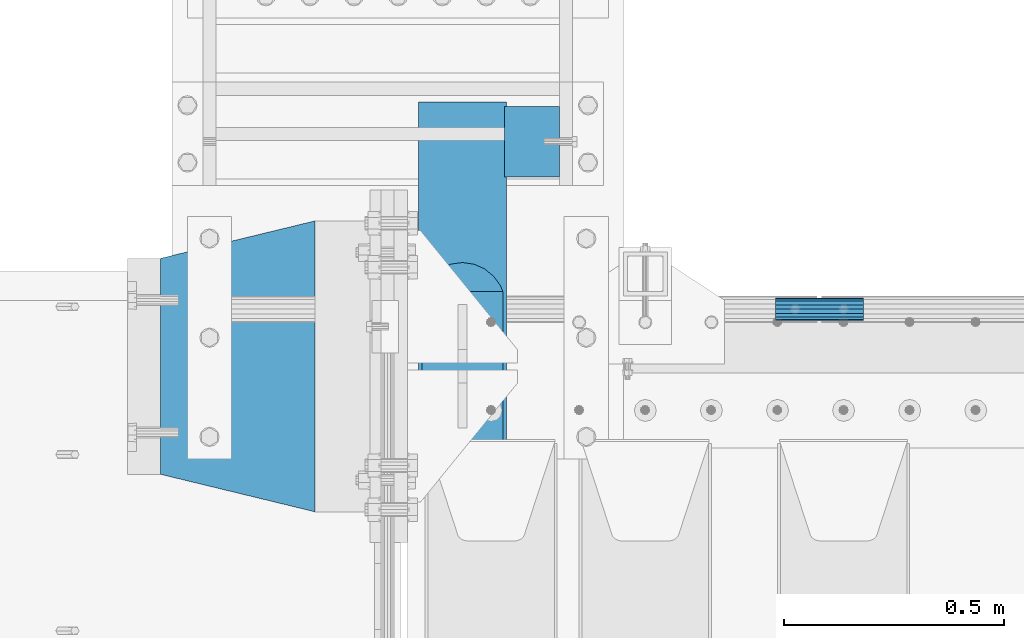
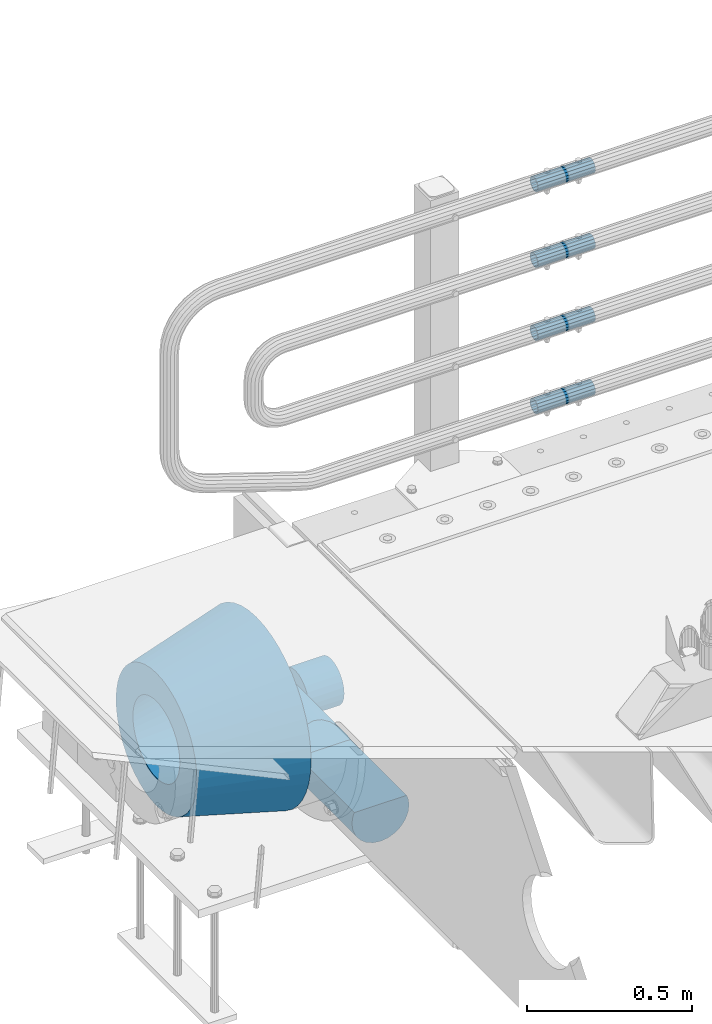
# One storey, part 113 of 193: 7 beams.
"""IFC2X3 building model written with IfcOpenShell, lengths in millimetres."""

from ifc_helpers import new_model, si_unit, frame, origin_with_axes, place, context, subcontext, project, spatial, faceted_brep, material, type_object, element, save


model = new_model("IFC2X3")

# Units and contexts
model_context = context("Model", 3, precision=1e-05, world=origin_with_axes())
body_context = subcontext(model_context, "Body", "Model", "MODEL_VIEW")
ifc_project = project(units=[si_unit("LENGTHUNIT", "METRE", prefix="MILLI"), si_unit("AREAUNIT", "SQUARE_METRE"), si_unit("VOLUMEUNIT", "CUBIC_METRE"), si_unit("MASSUNIT", "GRAM", prefix="KILO"), si_unit("TIMEUNIT", "SECOND"), si_unit("PLANEANGLEUNIT", "RADIAN"), si_unit("SOLIDANGLEUNIT", "STERADIAN"), si_unit("THERMODYNAMICTEMPERATUREUNIT", "DEGREE_CELSIUS"), si_unit("LUMINOUSINTENSITYUNIT", "LUMEN")], contexts=[model_context])

# Site, building, storey
site_placement = place(None, origin_with_axes())
site = spatial("IfcSite", under=ifc_project, at=site_placement, CompositionType="ELEMENT")
building_placement = place(site_placement, origin_with_axes())
building = spatial("IfcBuilding", under=site, at=building_placement, Name="Standard", CompositionType="ELEMENT")
storey_placement = place(building_placement, origin_with_axes())
storey = spatial("IfcBuildingStorey", under=building, at=storey_placement, Name="Undefined", CompositionType="ELEMENT", Elevation=0.0)

# Beams
ifc_material_1 = material(Name="STEEL/S355N")
beam_type_1 = type_object("IfcBeamType", Name="D200", PredefinedType="NOTDEFINED")
beam_1_placement = place(storey_placement, frame((-42315.0, 30600.0, -928.0), z_axis=(0.0, 0.0, 1.0), x_axis=(0.0, -1.0, 0.0)))
element("IfcBeam", 1, at=beam_1_placement, inside=storey, type_object=beam_type_1, material=ifc_material_1, ObjectType="D200", context=body_context, shape_type="Brep", body=[
    faceted_brep([(430.0, 91.573103126917, 38.0), (430.0, -91.5731031269243, 38.0), (770.0, -91.5731031269243, 37.9999999999994), (770.0, 91.5731031269243, 37.9999999999994), (417.294117647056, 86.6025403784442, 50.0), (395.365164344952, 70.7106781186521, 70.7106781186548), (378.538486658119, 50.0, 86.6025403784439), (367.960794863509, 25.88190451025, 96.5925826289068), (364.352941176472, 0.0, 100.0), (367.960794863509, -25.88190451025, 96.5925826289068), (378.538486658119, -50.0, 86.6025403784439), (395.365164344952, -70.7106781186521, 70.7106781186548), (417.294117647056, -86.6025403784442, 50.0), (0.0, -96.5925826289094, 25.8819045102521), (0.0, -100.0, 0.0), (770.0, -100.0, 0.0), (770.0, -96.5925826289094, 25.8819045102521), (0.0, 96.5925826289094, -25.8819045102521), (0.0, 100.0, 0.0), (770.0, 100.0, 0.0), (770.0, 96.5925826289094, -25.8819045102521), (0.0, 86.6025403784442, -50.0), (770.0, 86.6025403784442, -50.0), (0.0, 70.7106781186521, -70.7106781186548), (770.0, 70.7106781186521, -70.7106781186548), (0.0, 50.0, -86.6025403784438), (770.0, 50.0, -86.6025403784438), (0.0, 25.88190451025, -96.5925826289067), (770.0, 25.88190451025, -96.5925826289067), (0.0, 0.0, -100.0), (770.0, 0.0, -100.0), (0.0, -25.88190451025, -96.5925826289069), (770.0, -25.88190451025, -96.5925826289069), (0.0, -50.0, -86.6025403784439), (770.0, -50.0, -86.6025403784439), (0.0, -70.7106781186521, -70.7106781186548), (770.0, -70.7106781186521, -70.7106781186548), (0.0, -86.6025403784442, -50.0), (770.0, -86.6025403784442, -50.0), (0.0, -96.5925826289094, -25.8819045102522), (770.0, -96.5925826289094, -25.8819045102522), (0.0, -86.6025403784442, 50.0), (0.0, -70.7106781186521, 70.7106781186548), (0.0, -50.0, 86.6025403784439), (0.0, -25.88190451025, 96.5925826289068), (0.0, 0.0, 100.0), (0.0, 25.88190451025, 96.5925826289068), (0.0, 50.0, 86.6025403784439), (0.0, 70.7106781186521, 70.7106781186548), (0.0, 86.6025403784442, 50.0), (0.0, 96.5925826289094, 25.8819045102521), (770.0, 96.5925826289094, 25.8819045102521)], [[[0, 1, 2, 3]], [[4, 5, 6, 7, 8, 9, 10, 11, 12, 1, 0]], [[13, 14, 15, 16]], [[17, 18, 19, 20]], [[21, 17, 20, 22]], [[23, 21, 22, 24]], [[25, 23, 24, 26]], [[27, 25, 26, 28]], [[29, 27, 28, 30]], [[31, 29, 30, 32]], [[33, 31, 32, 34]], [[35, 33, 34, 36]], [[37, 35, 36, 38]], [[39, 37, 38, 40]], [[14, 39, 40, 15]], [[13, 41, 42, 43, 44, 45, 46, 47, 48, 49, 50, 18, 17, 21, 23, 25, 27, 29, 31, 33, 35, 37, 39, 14]], [[18, 50, 51, 19]], [[16, 15, 40, 38, 36, 34, 32, 30, 28, 26, 24, 22, 20, 19, 51, 3, 2]], [[41, 13, 16, 2, 1, 12]], [[42, 41, 12, 11]], [[43, 42, 11, 10]], [[44, 43, 10, 9]], [[45, 44, 9, 8]], [[46, 45, 8, 7]], [[47, 46, 7, 6]], [[48, 47, 6, 5]], [[49, 48, 5, 4]], [[51, 50, 49, 4, 0, 3]]]),
])
ifc_material_2 = material()
beam_type_2 = type_object("IfcBeamType", PredefinedType="NOTDEFINED")
beam_2_placement = place(storey_placement, frame((-42220.0000000006, 30509.9999999997, -923.000000000004), z_axis=(0.0, 0.0, 1.0), x_axis=(1.0, 0.0, 0.0)))
element("IfcBeam", 2, at=beam_2_placement, inside=storey, type_object=beam_type_2, material=ifc_material_2, context=body_context, shape_type="Brep", body=[
    faceted_brep([(0.0, -80.0, 0.0), (0.0, -77.2740661031239, -20.7055236082017), (125.0, -77.2740661031239, -20.7055236082017), (125.0, -80.0, 0.0), (0.0, -69.2820323027554, -40.0), (125.0, -69.2820323027554, -40.0), (0.0, -56.5685424949224, -56.5685424949238), (125.0, -56.5685424949224, -56.5685424949238), (0.0, -40.0, -69.2820323027552), (125.0, -40.0, -69.2820323027552), (0.0, -20.7055236082015, -77.2740661031255), (125.0, -20.7055236082015, -77.2740661031255), (0.0, 0.0, -80.0), (125.0, 0.0, -80.0), (0.0, 20.7055236082015, -77.2740661031255), (125.0, 20.7055236082015, -77.2740661031255), (0.0, 40.0, -69.2820323027551), (125.0, 40.0, -69.2820323027551), (0.0, 56.5685424949224, -56.5685424949238), (125.0, 56.5685424949224, -56.5685424949238), (0.0, 69.2820323027554, -40.0), (125.0, 69.2820323027554, -40.0), (0.0, 77.2740661031239, -20.7055236082016), (125.0, 77.2740661031239, -20.7055236082016), (0.0, 80.0, 0.0), (125.0, 80.0, 0.0), (0.0, 77.2740661031239, 20.7055236082017), (125.0, 77.2740661031239, 20.7055236082017), (0.0, 69.2820323027554, 40.0), (125.0, 69.2820323027554, 40.0), (0.0, 56.5685424949224, 56.5685424949238), (125.0, 56.5685424949224, 56.5685424949238), (0.0, 40.0, 69.2820323027551), (125.0, 40.0, 69.2820323027551), (0.0, 20.7055236082015, 77.2740661031255), (125.0, 20.7055236082015, 77.2740661031255), (0.0, 0.0, 80.0), (125.0, 0.0, 80.0), (0.0, -20.7055236082015, 77.2740661031255), (125.0, -20.7055236082015, 77.2740661031255), (0.0, -40.0, 69.2820323027551), (125.0, -40.0, 69.2820323027551), (0.0, -56.5685424949224, 56.5685424949238), (125.0, -56.5685424949224, 56.5685424949238), (0.0, -69.2820323027554, 40.0), (125.0, -69.2820323027554, 40.0), (0.0, -77.2740661031239, 20.7055236082017), (125.0, -77.2740661031239, 20.7055236082017)], [[[0, 1, 2, 3]], [[1, 4, 5, 2]], [[4, 6, 7, 5]], [[6, 8, 9, 7]], [[8, 10, 11, 9]], [[10, 12, 13, 11]], [[12, 14, 15, 13]], [[14, 16, 17, 15]], [[16, 18, 19, 17]], [[18, 20, 21, 19]], [[20, 22, 23, 21]], [[22, 24, 25, 23]], [[24, 26, 27, 25]], [[26, 28, 29, 27]], [[28, 30, 31, 29]], [[30, 32, 33, 31]], [[32, 34, 35, 33]], [[34, 36, 37, 35]], [[36, 38, 39, 37]], [[38, 40, 41, 39]], [[40, 42, 43, 41]], [[42, 44, 45, 43]], [[44, 46, 47, 45]], [[46, 0, 3, 47]], [[5, 7, 9, 11, 13, 15, 17, 19, 21, 23, 25, 27, 29, 31, 33, 35, 37, 39, 41, 43, 45, 47, 3, 2]], [[46, 44, 42, 40, 38, 36, 34, 32, 30, 28, 26, 24, 22, 20, 18, 16, 14, 12, 10, 8, 6, 4, 1, 0]]]),
])
ifc_material_3 = material()
beam_type_3 = type_object("IfcBeamType", PredefinedType="NOTDEFINED")
beam_3_placement = place(storey_placement, frame((-41605.0024970001, 30129.8500000004, 149.849999999747), z_axis=(0.0, 0.0, 1.0), x_axis=(1.0, 0.0, 0.0)))
element("IfcBeam", 3, at=beam_3_placement, inside=storey, type_object=beam_type_3, material=ifc_material_3, context=body_context, shape_type="Brep", body=[
    faceted_brep([(0.0, -21.9000000000015, 0.0), (0.0, -20.232961761998, 8.38076716879547), (200.0, -20.232961761998, 8.38076716879547), (200.0, -21.9000000000015, 0.0), (0.0, -15.4856385079838, 15.4856385079854), (200.0, -15.4856385079838, 15.4856385079854), (0.0, -8.38076716879368, 20.2329617619972), (200.0, -8.38076716879368, 20.2329617619972), (0.0, 0.0, 21.9), (200.0, 0.0, 21.9), (0.0, 8.38076716879368, 20.2329617619972), (200.0, 8.38076716879368, 20.2329617619972), (0.0, 15.4856385079838, 15.4856385079854), (200.0, 15.4856385079838, 15.4856385079854), (0.0, 20.232961761998, 8.38076716879547), (200.0, 20.232961761998, 8.38076716879547), (0.0, 21.9000000000015, 0.0), (200.0, 21.9000000000015, 0.0), (0.0, 20.232961761998, -8.38076716879547), (200.0, 20.232961761998, -8.38076716879547), (0.0, 15.4856385079838, -15.4856385079854), (200.0, 15.4856385079838, -15.4856385079854), (0.0, 8.38076716879368, -20.2329617619972), (200.0, 8.38076716879368, -20.2329617619972), (0.0, 0.0, -21.9), (200.0, 0.0, -21.9), (0.0, -8.38076716879368, -20.2329617619972), (200.0, -8.38076716879368, -20.2329617619972), (0.0, -15.4856385079838, -15.4856385079854), (200.0, -15.4856385079838, -15.4856385079854), (0.0, -20.232961761998, -8.38076716879547), (200.0, -20.232961761998, -8.38076716879547), (0.0, -25.5, 0.0), (0.0, -23.5589280790373, -9.7584275253098), (200.0, -23.5589280790373, -9.7584275253098), (200.0, -25.5, 0.0), (0.0, -18.0312229202573, -18.031222920257), (200.0, -18.0312229202573, -18.031222920257), (0.0, -9.75842752531025, -23.5589280790378), (200.0, -9.75842752531025, -23.5589280790378), (0.0, 0.0, -25.5), (200.0, 0.0, -25.5), (0.0, 9.75842752531025, -23.5589280790378), (200.0, 9.75842752531025, -23.5589280790378), (0.0, 18.0312229202573, -18.031222920257), (200.0, 18.0312229202573, -18.031222920257), (0.0, 23.5589280790373, -9.7584275253098), (200.0, 23.5589280790373, -9.7584275253098), (0.0, 25.5, 0.0), (200.0, 25.5, 0.0), (0.0, 23.5589280790373, 9.7584275253098), (200.0, 23.5589280790373, 9.7584275253098), (0.0, 18.0312229202573, 18.031222920257), (200.0, 18.0312229202573, 18.031222920257), (0.0, 9.75842752531025, 23.5589280790378), (200.0, 9.75842752531025, 23.5589280790378), (0.0, 0.0, 25.5), (200.0, 0.0, 25.5), (0.0, -9.75842752531025, 23.5589280790378), (200.0, -9.75842752531025, 23.5589280790378), (0.0, -18.0312229202573, 18.031222920257), (200.0, -18.0312229202573, 18.031222920257), (0.0, -23.5589280790373, 9.7584275253098), (200.0, -23.5589280790373, 9.7584275253098)], [[[0, 1, 2, 3]], [[1, 4, 5, 2]], [[4, 6, 7, 5]], [[6, 8, 9, 7]], [[8, 10, 11, 9]], [[10, 12, 13, 11]], [[12, 14, 15, 13]], [[14, 16, 17, 15]], [[16, 18, 19, 17]], [[18, 20, 21, 19]], [[20, 22, 23, 21]], [[22, 24, 25, 23]], [[24, 26, 27, 25]], [[26, 28, 29, 27]], [[28, 30, 31, 29]], [[30, 0, 3, 31]], [[32, 33, 34, 35]], [[33, 36, 37, 34]], [[36, 38, 39, 37]], [[38, 40, 41, 39]], [[40, 42, 43, 41]], [[42, 44, 45, 43]], [[44, 46, 47, 45]], [[46, 48, 49, 47]], [[48, 50, 51, 49]], [[50, 52, 53, 51]], [[52, 54, 55, 53]], [[54, 56, 57, 55]], [[56, 58, 59, 57]], [[58, 60, 61, 59]], [[60, 62, 63, 61]], [[62, 32, 35, 63]], [[37, 39, 41, 43, 45, 47, 49, 51, 53, 55, 57, 59, 61, 63, 35, 34], [5, 7, 9, 11, 13, 15, 17, 19, 21, 23, 25, 27, 29, 31, 3, 2]], [[62, 60, 58, 56, 54, 52, 50, 48, 46, 44, 42, 40, 38, 36, 33, 32], [30, 28, 26, 24, 22, 20, 18, 16, 14, 12, 10, 8, 6, 4, 1, 0]]]),
])
beam_4_placement = place(storey_placement, frame((-41605.0024970001, 30129.8500000004, 420.149999999747), z_axis=(0.0, 0.0, 1.0), x_axis=(1.0, 0.0, 0.0)))
element("IfcBeam", 4, at=beam_4_placement, inside=storey, type_object=beam_type_3, material=ifc_material_3, context=body_context, shape_type="Brep", body=[
    faceted_brep([(0.0, -21.9000000000015, 0.0), (0.0, -20.232961761998, 8.38076716879547), (200.0, -20.232961761998, 8.38076716879547), (200.0, -21.9000000000015, 0.0), (0.0, -15.4856385079838, 15.4856385079854), (200.0, -15.4856385079838, 15.4856385079854), (0.0, -8.38076716879368, 20.2329617619972), (200.0, -8.38076716879368, 20.2329617619972), (0.0, 0.0, 21.9), (200.0, 0.0, 21.9), (0.0, 8.38076716879368, 20.2329617619972), (200.0, 8.38076716879368, 20.2329617619972), (0.0, 15.4856385079838, 15.4856385079854), (200.0, 15.4856385079838, 15.4856385079854), (0.0, 20.232961761998, 8.38076716879547), (200.0, 20.232961761998, 8.38076716879547), (0.0, 21.9000000000015, 0.0), (200.0, 21.9000000000015, 0.0), (0.0, 20.232961761998, -8.38076716879547), (200.0, 20.232961761998, -8.38076716879547), (0.0, 15.4856385079838, -15.4856385079854), (200.0, 15.4856385079838, -15.4856385079854), (0.0, 8.38076716879368, -20.2329617619972), (200.0, 8.38076716879368, -20.2329617619972), (0.0, 0.0, -21.9), (200.0, 0.0, -21.9), (0.0, -8.38076716879368, -20.2329617619972), (200.0, -8.38076716879368, -20.2329617619972), (0.0, -15.4856385079838, -15.4856385079854), (200.0, -15.4856385079838, -15.4856385079854), (0.0, -20.232961761998, -8.38076716879547), (200.0, -20.232961761998, -8.38076716879547), (0.0, -25.5, 0.0), (0.0, -23.5589280790373, -9.7584275253098), (200.0, -23.5589280790373, -9.7584275253098), (200.0, -25.5, 0.0), (0.0, -18.0312229202573, -18.031222920257), (200.0, -18.0312229202573, -18.031222920257), (0.0, -9.75842752531025, -23.5589280790378), (200.0, -9.75842752531025, -23.5589280790378), (0.0, 0.0, -25.5), (200.0, 0.0, -25.5), (0.0, 9.75842752531025, -23.5589280790378), (200.0, 9.75842752531025, -23.5589280790378), (0.0, 18.0312229202573, -18.031222920257), (200.0, 18.0312229202573, -18.031222920257), (0.0, 23.5589280790373, -9.7584275253098), (200.0, 23.5589280790373, -9.7584275253098), (0.0, 25.5, 0.0), (200.0, 25.5, 0.0), (0.0, 23.5589280790373, 9.7584275253098), (200.0, 23.5589280790373, 9.7584275253098), (0.0, 18.0312229202573, 18.031222920257), (200.0, 18.0312229202573, 18.031222920257), (0.0, 9.75842752531025, 23.5589280790378), (200.0, 9.75842752531025, 23.5589280790378), (0.0, 0.0, 25.5), (200.0, 0.0, 25.5), (0.0, -9.75842752531025, 23.5589280790378), (200.0, -9.75842752531025, 23.5589280790378), (0.0, -18.0312229202573, 18.031222920257), (200.0, -18.0312229202573, 18.031222920257), (0.0, -23.5589280790373, 9.7584275253098), (200.0, -23.5589280790373, 9.7584275253098)], [[[0, 1, 2, 3]], [[1, 4, 5, 2]], [[4, 6, 7, 5]], [[6, 8, 9, 7]], [[8, 10, 11, 9]], [[10, 12, 13, 11]], [[12, 14, 15, 13]], [[14, 16, 17, 15]], [[16, 18, 19, 17]], [[18, 20, 21, 19]], [[20, 22, 23, 21]], [[22, 24, 25, 23]], [[24, 26, 27, 25]], [[26, 28, 29, 27]], [[28, 30, 31, 29]], [[30, 0, 3, 31]], [[32, 33, 34, 35]], [[33, 36, 37, 34]], [[36, 38, 39, 37]], [[38, 40, 41, 39]], [[40, 42, 43, 41]], [[42, 44, 45, 43]], [[44, 46, 47, 45]], [[46, 48, 49, 47]], [[48, 50, 51, 49]], [[50, 52, 53, 51]], [[52, 54, 55, 53]], [[54, 56, 57, 55]], [[56, 58, 59, 57]], [[58, 60, 61, 59]], [[60, 62, 63, 61]], [[62, 32, 35, 63]], [[37, 39, 41, 43, 45, 47, 49, 51, 53, 55, 57, 59, 61, 63, 35, 34], [5, 7, 9, 11, 13, 15, 17, 19, 21, 23, 25, 27, 29, 31, 3, 2]], [[62, 60, 58, 56, 54, 52, 50, 48, 46, 44, 42, 40, 38, 36, 33, 32], [30, 28, 26, 24, 22, 20, 18, 16, 14, 12, 10, 8, 6, 4, 1, 0]]]),
])
beam_5_placement = place(storey_placement, frame((-41605.0024970001, 30129.8500000004, 969.849999999747), z_axis=(0.0, 0.0, 1.0), x_axis=(1.0, 0.0, 0.0)))
element("IfcBeam", 5, at=beam_5_placement, inside=storey, type_object=beam_type_3, material=ifc_material_3, context=body_context, shape_type="Brep", body=[
    faceted_brep([(0.0, -21.9000000000015, 0.0), (0.0, -20.232961761998, 8.38076716879547), (200.0, -20.232961761998, 8.38076716879547), (200.0, -21.9000000000015, 0.0), (0.0, -15.4856385079838, 15.4856385079854), (200.0, -15.4856385079838, 15.4856385079854), (0.0, -8.38076716879368, 20.2329617619972), (200.0, -8.38076716879368, 20.2329617619972), (0.0, 0.0, 21.9), (200.0, 0.0, 21.9), (0.0, 8.38076716879368, 20.2329617619972), (200.0, 8.38076716879368, 20.2329617619972), (0.0, 15.4856385079838, 15.4856385079854), (200.0, 15.4856385079838, 15.4856385079854), (0.0, 20.232961761998, 8.38076716879547), (200.0, 20.232961761998, 8.38076716879547), (0.0, 21.9000000000015, 0.0), (200.0, 21.9000000000015, 0.0), (0.0, 20.232961761998, -8.38076716879547), (200.0, 20.232961761998, -8.38076716879547), (0.0, 15.4856385079838, -15.4856385079854), (200.0, 15.4856385079838, -15.4856385079854), (0.0, 8.38076716879368, -20.2329617619972), (200.0, 8.38076716879368, -20.2329617619972), (0.0, 0.0, -21.9), (200.0, 0.0, -21.9), (0.0, -8.38076716879368, -20.2329617619972), (200.0, -8.38076716879368, -20.2329617619972), (0.0, -15.4856385079838, -15.4856385079854), (200.0, -15.4856385079838, -15.4856385079854), (0.0, -20.232961761998, -8.38076716879547), (200.0, -20.232961761998, -8.38076716879547), (0.0, -25.5, 0.0), (0.0, -23.5589280790373, -9.7584275253098), (200.0, -23.5589280790373, -9.7584275253098), (200.0, -25.5, 0.0), (0.0, -18.0312229202573, -18.031222920257), (200.0, -18.0312229202573, -18.031222920257), (0.0, -9.75842752531025, -23.5589280790378), (200.0, -9.75842752531025, -23.5589280790378), (0.0, 0.0, -25.5), (200.0, 0.0, -25.5), (0.0, 9.75842752531025, -23.5589280790378), (200.0, 9.75842752531025, -23.5589280790378), (0.0, 18.0312229202573, -18.031222920257), (200.0, 18.0312229202573, -18.031222920257), (0.0, 23.5589280790373, -9.7584275253098), (200.0, 23.5589280790373, -9.7584275253098), (0.0, 25.5, 0.0), (200.0, 25.5, 0.0), (0.0, 23.5589280790373, 9.7584275253098), (200.0, 23.5589280790373, 9.7584275253098), (0.0, 18.0312229202573, 18.031222920257), (200.0, 18.0312229202573, 18.031222920257), (0.0, 9.75842752531025, 23.5589280790378), (200.0, 9.75842752531025, 23.5589280790378), (0.0, 0.0, 25.5), (200.0, 0.0, 25.5), (0.0, -9.75842752531025, 23.5589280790378), (200.0, -9.75842752531025, 23.5589280790378), (0.0, -18.0312229202573, 18.031222920257), (200.0, -18.0312229202573, 18.031222920257), (0.0, -23.5589280790373, 9.7584275253098), (200.0, -23.5589280790373, 9.7584275253098)], [[[0, 1, 2, 3]], [[1, 4, 5, 2]], [[4, 6, 7, 5]], [[6, 8, 9, 7]], [[8, 10, 11, 9]], [[10, 12, 13, 11]], [[12, 14, 15, 13]], [[14, 16, 17, 15]], [[16, 18, 19, 17]], [[18, 20, 21, 19]], [[20, 22, 23, 21]], [[22, 24, 25, 23]], [[24, 26, 27, 25]], [[26, 28, 29, 27]], [[28, 30, 31, 29]], [[30, 0, 3, 31]], [[32, 33, 34, 35]], [[33, 36, 37, 34]], [[36, 38, 39, 37]], [[38, 40, 41, 39]], [[40, 42, 43, 41]], [[42, 44, 45, 43]], [[44, 46, 47, 45]], [[46, 48, 49, 47]], [[48, 50, 51, 49]], [[50, 52, 53, 51]], [[52, 54, 55, 53]], [[54, 56, 57, 55]], [[56, 58, 59, 57]], [[58, 60, 61, 59]], [[60, 62, 63, 61]], [[62, 32, 35, 63]], [[37, 39, 41, 43, 45, 47, 49, 51, 53, 55, 57, 59, 61, 63, 35, 34], [5, 7, 9, 11, 13, 15, 17, 19, 21, 23, 25, 27, 29, 31, 3, 2]], [[62, 60, 58, 56, 54, 52, 50, 48, 46, 44, 42, 40, 38, 36, 33, 32], [30, 28, 26, 24, 22, 20, 18, 16, 14, 12, 10, 8, 6, 4, 1, 0]]]),
])
beam_6_placement = place(storey_placement, frame((-41605.0024970001, 30129.8500000004, 689.849999999747), z_axis=(0.0, 0.0, 1.0), x_axis=(1.0, 0.0, 0.0)))
element("IfcBeam", 6, at=beam_6_placement, inside=storey, type_object=beam_type_3, material=ifc_material_3, context=body_context, shape_type="Brep", body=[
    faceted_brep([(0.0, -21.9000000000015, 0.0), (0.0, -20.232961761998, 8.38076716879547), (200.0, -20.232961761998, 8.38076716879547), (200.0, -21.9000000000015, 0.0), (0.0, -15.4856385079838, 15.4856385079854), (200.0, -15.4856385079838, 15.4856385079854), (0.0, -8.38076716879368, 20.2329617619972), (200.0, -8.38076716879368, 20.2329617619972), (0.0, 0.0, 21.9), (200.0, 0.0, 21.9), (0.0, 8.38076716879368, 20.2329617619972), (200.0, 8.38076716879368, 20.2329617619972), (0.0, 15.4856385079838, 15.4856385079854), (200.0, 15.4856385079838, 15.4856385079854), (0.0, 20.232961761998, 8.38076716879547), (200.0, 20.232961761998, 8.38076716879547), (0.0, 21.9000000000015, 0.0), (200.0, 21.9000000000015, 0.0), (0.0, 20.232961761998, -8.38076716879547), (200.0, 20.232961761998, -8.38076716879547), (0.0, 15.4856385079838, -15.4856385079854), (200.0, 15.4856385079838, -15.4856385079854), (0.0, 8.38076716879368, -20.2329617619972), (200.0, 8.38076716879368, -20.2329617619972), (0.0, 0.0, -21.9), (200.0, 0.0, -21.9), (0.0, -8.38076716879368, -20.2329617619972), (200.0, -8.38076716879368, -20.2329617619972), (0.0, -15.4856385079838, -15.4856385079854), (200.0, -15.4856385079838, -15.4856385079854), (0.0, -20.232961761998, -8.38076716879547), (200.0, -20.232961761998, -8.38076716879547), (0.0, -25.5, 0.0), (0.0, -23.5589280790373, -9.7584275253098), (200.0, -23.5589280790373, -9.7584275253098), (200.0, -25.5, 0.0), (0.0, -18.0312229202573, -18.031222920257), (200.0, -18.0312229202573, -18.031222920257), (0.0, -9.75842752531025, -23.5589280790378), (200.0, -9.75842752531025, -23.5589280790378), (0.0, 0.0, -25.5), (200.0, 0.0, -25.5), (0.0, 9.75842752531025, -23.5589280790378), (200.0, 9.75842752531025, -23.5589280790378), (0.0, 18.0312229202573, -18.031222920257), (200.0, 18.0312229202573, -18.031222920257), (0.0, 23.5589280790373, -9.7584275253098), (200.0, 23.5589280790373, -9.7584275253098), (0.0, 25.5, 0.0), (200.0, 25.5, 0.0), (0.0, 23.5589280790373, 9.7584275253098), (200.0, 23.5589280790373, 9.7584275253098), (0.0, 18.0312229202573, 18.031222920257), (200.0, 18.0312229202573, 18.031222920257), (0.0, 9.75842752531025, 23.5589280790378), (200.0, 9.75842752531025, 23.5589280790378), (0.0, 0.0, 25.5), (200.0, 0.0, 25.5), (0.0, -9.75842752531025, 23.5589280790378), (200.0, -9.75842752531025, 23.5589280790378), (0.0, -18.0312229202573, 18.031222920257), (200.0, -18.0312229202573, 18.031222920257), (0.0, -23.5589280790373, 9.7584275253098), (200.0, -23.5589280790373, 9.7584275253098)], [[[0, 1, 2, 3]], [[1, 4, 5, 2]], [[4, 6, 7, 5]], [[6, 8, 9, 7]], [[8, 10, 11, 9]], [[10, 12, 13, 11]], [[12, 14, 15, 13]], [[14, 16, 17, 15]], [[16, 18, 19, 17]], [[18, 20, 21, 19]], [[20, 22, 23, 21]], [[22, 24, 25, 23]], [[24, 26, 27, 25]], [[26, 28, 29, 27]], [[28, 30, 31, 29]], [[30, 0, 3, 31]], [[32, 33, 34, 35]], [[33, 36, 37, 34]], [[36, 38, 39, 37]], [[38, 40, 41, 39]], [[40, 42, 43, 41]], [[42, 44, 45, 43]], [[44, 46, 47, 45]], [[46, 48, 49, 47]], [[48, 50, 51, 49]], [[50, 52, 53, 51]], [[52, 54, 55, 53]], [[54, 56, 57, 55]], [[56, 58, 59, 57]], [[58, 60, 61, 59]], [[60, 62, 63, 61]], [[62, 32, 35, 63]], [[37, 39, 41, 43, 45, 47, 49, 51, 53, 55, 57, 59, 61, 63, 35, 34], [5, 7, 9, 11, 13, 15, 17, 19, 21, 23, 25, 27, 29, 31, 3, 2]], [[62, 60, 58, 56, 54, 52, 50, 48, 46, 44, 42, 40, 38, 36, 33, 32], [30, 28, 26, 24, 22, 20, 18, 16, 14, 12, 10, 8, 6, 4, 1, 0]]]),
])
ifc_material_4 = material(Name="SCN-500-E2")
beam_type_4 = type_object("IfcBeamType", PredefinedType="NOTDEFINED")
beam_7_placement = place(storey_placement, frame((-42650.0, 30000.0, -515.0), z_axis=(0.0, 0.0, 1.0), x_axis=(-1.0, 0.0, 0.0)))
element("IfcBeam", 7, at=beam_7_placement, inside=storey, type_object=beam_type_4, material=ifc_material_4, context=body_context, shape_type="Brep", body=[
    faceted_brep([(0.0, -330.0, 0.0), (0.0, -326.641075820709, -46.9638966301842), (350.0, -242.506253260828, -34.8671353769549), (350.0, -245.0, 0.0), (0.0, -316.632681292784, -92.9717437576718), (350.0, -235.075778535553, -69.0244764261503), (0.0, -300.178558466992, -137.086954290623), (350.0, -222.859838861856, -101.776678185462), (0.0, -277.613665834291, -178.411469760347), (350.0, -206.10711554364, -132.457000276621), (0.0, -249.397359536906, -216.104042201944), (350.0, -185.158645716794, -160.440879816595), (0.0, -216.104042201943, -249.397359536905), (350.0, -160.440879816593, -185.158645716793), (0.0, -178.411469760347, -277.61366583429), (350.0, -132.45700027662, -206.107115543639), (0.0, -137.086954290622, -300.178558466991), (350.0, -101.776678185463, -222.859838861857), (0.0, -92.9717437576728, -316.632681292784), (350.0, -69.0244764261515, -235.075778535552), (0.0, -46.9638966301827, -326.641075820708), (350.0, -34.8671353769532, -242.506253260829), (0.0, 0.0, -330.0), (350.0, 0.0, -245.0), (0.0, 46.9638966301827, -326.641075820708), (350.0, 34.8671353769532, -242.506253260829), (0.0, 92.9717437576728, -316.632681292784), (350.0, 69.0244764261515, -235.075778535552), (0.0, 137.086954290622, -300.178558466991), (350.0, 101.776678185463, -222.859838861857), (0.0, 178.411469760347, -277.61366583429), (350.0, 132.457000276623, -206.107115543639), (0.0, 216.104042201943, -249.397359536905), (350.0, 160.440879816593, -185.158645716793), (0.0, 249.397359536906, -216.104042201944), (350.0, 185.158645716794, -160.440879816595), (0.0, 277.613665834291, -178.411469760347), (350.0, 206.10711554364, -132.457000276621), (0.0, 300.178558466992, -137.086954290623), (350.0, 222.859838861856, -101.776678185462), (0.0, 316.632681292784, -92.9717437576717), (350.0, 235.075778535553, -69.0244764261502), (0.0, 326.641075820709, -46.9638966301841), (350.0, 242.506253260828, -34.8671353769548), (0.0, 330.0, 0.0), (350.0, 245.0, 0.0), (0.0, 326.641075820709, 46.9638966301841), (350.0, 242.506253260828, 34.8671353769549), (0.0, 316.632681292784, 92.9717437576718), (350.0, 235.075778535553, 69.0244764261503), (0.0, 300.178558466992, 137.086954290622), (350.0, 222.859838861856, 101.776678185462), (0.0, 277.613665834291, 178.411469760347), (350.0, 206.10711554364, 132.457000276621), (0.0, 249.397359536906, 216.104042201944), (350.0, 185.158645716794, 160.440879816595), (0.0, 216.104042201943, 249.397359536905), (350.0, 160.440879816593, 185.158645716793), (0.0, 178.411469760347, 277.61366583429), (350.0, 132.457000276623, 206.107115543639), (0.0, 137.086954290622, 300.178558466991), (350.0, 101.776678185463, 222.859838861857), (0.0, 92.9717437576728, 316.632681292784), (350.0, 69.0244764261515, 235.075778535552), (0.0, 46.9638966301827, 326.641075820708), (350.0, 34.8671353769532, 242.506253260829), (0.0, 0.0, 330.0), (350.0, 0.0, 245.0), (0.0, -46.9638966301827, 326.641075820708), (350.0, -34.8671353769532, 242.506253260829), (0.0, -92.9717437576728, 316.632681292784), (350.0, -69.0244764261515, 235.075778535552), (0.0, -137.086954290622, 300.178558466991), (350.0, -101.776678185463, 222.859838861857), (0.0, -178.411469760347, 277.61366583429), (350.0, -132.457000276623, 206.107115543639), (0.0, -216.104042201943, 249.397359536905), (350.0, -160.440879816593, 185.158645716793), (0.0, -249.397359536906, 216.104042201944), (350.0, -185.158645716794, 160.440879816595), (0.0, -277.613665834291, 178.411469760347), (350.0, -206.10711554364, 132.457000276621), (0.0, -300.178558466992, 137.086954290623), (350.0, -222.859838861856, 101.776678185462), (0.0, -316.632681292784, 92.9717437576718), (350.0, -235.075778535553, 69.0244764261503), (0.0, -326.641075820709, 46.9638966301841), (350.0, -242.506253260828, 34.8671353769549), (0.0, -227.093265923133, 0.0), (0.0, -224.781783917482, 32.3187414128026), (350.0, -140.646961357605, 20.2219801595734), (350.0, -142.093265923133, 0.0), (0.0, -217.894393008413, 63.9795664499945), (350.0, -136.337490251182, 40.032299118473), (0.0, -206.571300613232, 94.3379520160985), (350.0, -129.252581008099, 59.0276759109381), (0.0, -191.043012240007, 122.775888927343), (350.0, -119.536461949356, 76.8214194436173), (0.0, -171.625639060127, 148.714462796454), (350.0, -107.386925240015, 93.0513004111044), (0.0, -148.714462796455, 171.625639060125), (350.0, -93.0513004111053, 107.386925240013), (0.0, -122.775888927343, 191.043012240005), (350.0, -76.8214194436187, 119.536461949355), (0.0, -94.3379520160997, 206.571300613232), (350.0, -59.0276759109365, 129.252581008098), (0.0, -63.9795664499943, 217.894393008413), (350.0, -40.032299118473, 136.337490251181), (0.0, -32.3187414128042, 224.781783917484), (350.0, -20.2219801595747, 140.646961357605), (0.0, 0.0, 227.093265923131), (350.0, 0.0, 142.093265923131), (0.0, 32.3187414128042, 224.781783917484), (350.0, 20.2219801595747, 140.646961357605), (0.0, 63.9795664499943, 217.894393008413), (350.0, 40.032299118473, 136.337490251181), (0.0, 94.3379520160997, 206.571300613232), (350.0, 59.0276759109365, 129.252581008098), (0.0, 122.775888927343, 191.043012240005), (350.0, 76.8214194436187, 119.536461949355), (0.0, 148.714462796455, 171.625639060125), (350.0, 93.0513004111053, 107.386925240013), (0.0, 171.625639060127, 148.714462796454), (350.0, 107.386925240015, 93.0513004111044), (0.0, 191.043012240007, 122.775888927343), (350.0, 119.536461949356, 76.8214194436174), (0.0, 206.571300613232, 94.3379520160985), (350.0, 129.252581008099, 59.0276759109382), (0.0, 217.894393008413, 63.9795664499945), (350.0, 136.337490251182, 40.032299118473), (0.0, 224.781783917482, 32.3187414128025), (350.0, 140.646961357605, 20.2219801595733), (0.0, 227.093265923133, 0.0), (350.0, 142.093265923133, 0.0), (0.0, 224.781783917482, -32.3187414128026), (350.0, 140.646961357605, -20.2219801595734), (0.0, 217.894393008413, -63.9795664499945), (350.0, 136.337490251182, -40.032299118473), (0.0, 206.571300613232, -94.3379520160985), (350.0, 129.252581008099, -59.0276759109381), (0.0, 191.043012240007, -122.775888927343), (350.0, 119.536461949356, -76.8214194436174), (0.0, 171.625639060127, -148.714462796454), (350.0, 107.386925240015, -93.0513004111044), (0.0, 148.714462796455, -171.625639060125), (350.0, 93.0513004111053, -107.386925240013), (0.0, 122.775888927343, -191.043012240005), (350.0, 76.8214194436187, -119.536461949355), (0.0, 94.3379520160997, -206.571300613232), (350.0, 59.0276759109365, -129.252581008098), (0.0, 63.9795664499943, -217.894393008413), (350.0, 40.032299118473, -136.337490251181), (0.0, 32.3187414128042, -224.781783917484), (350.0, 20.2219801595747, -140.646961357605), (0.0, 0.0, -227.093265923131), (350.0, 0.0, -142.093265923131), (0.0, -32.3187414128042, -224.781783917484), (350.0, -20.2219801595747, -140.646961357605), (0.0, -63.9795664499943, -217.894393008413), (350.0, -40.032299118473, -136.337490251181), (0.0, -94.3379520160997, -206.571300613232), (350.0, -59.0276759109365, -129.252581008098), (0.0, -122.775888927343, -191.043012240005), (350.0, -76.8214194436187, -119.536461949355), (0.0, -148.714462796455, -171.625639060125), (350.0, -93.0513004111053, -107.386925240013), (0.0, -171.625639060127, -148.714462796454), (350.0, -107.386925240015, -93.0513004111044), (0.0, -191.043012240007, -122.775888927343), (350.0, -119.536461949356, -76.8214194436174), (0.0, -206.571300613232, -94.3379520160985), (350.0, -129.252581008099, -59.0276759109381), (0.0, -217.894393008413, -63.9795664499945), (350.0, -136.337490251182, -40.032299118473), (0.0, -224.781783917482, -32.3187414128026), (350.0, -140.646961357605, -20.2219801595734)], [[[0, 1, 2, 3]], [[1, 4, 5, 2]], [[4, 6, 7, 5]], [[6, 8, 9, 7]], [[8, 10, 11, 9]], [[10, 12, 13, 11]], [[12, 14, 15, 13]], [[14, 16, 17, 15]], [[16, 18, 19, 17]], [[18, 20, 21, 19]], [[20, 22, 23, 21]], [[22, 24, 25, 23]], [[24, 26, 27, 25]], [[26, 28, 29, 27]], [[28, 30, 31, 29]], [[30, 32, 33, 31]], [[32, 34, 35, 33]], [[34, 36, 37, 35]], [[36, 38, 39, 37]], [[38, 40, 41, 39]], [[40, 42, 43, 41]], [[42, 44, 45, 43]], [[44, 46, 47, 45]], [[46, 48, 49, 47]], [[48, 50, 51, 49]], [[50, 52, 53, 51]], [[52, 54, 55, 53]], [[54, 56, 57, 55]], [[56, 58, 59, 57]], [[58, 60, 61, 59]], [[60, 62, 63, 61]], [[62, 64, 65, 63]], [[64, 66, 67, 65]], [[66, 68, 69, 67]], [[68, 70, 71, 69]], [[70, 72, 73, 71]], [[72, 74, 75, 73]], [[74, 76, 77, 75]], [[76, 78, 79, 77]], [[78, 80, 81, 79]], [[80, 82, 83, 81]], [[82, 84, 85, 83]], [[84, 86, 87, 85]], [[86, 0, 3, 87]], [[88, 89, 90, 91]], [[89, 92, 93, 90]], [[92, 94, 95, 93]], [[94, 96, 97, 95]], [[96, 98, 99, 97]], [[98, 100, 101, 99]], [[100, 102, 103, 101]], [[102, 104, 105, 103]], [[104, 106, 107, 105]], [[106, 108, 109, 107]], [[108, 110, 111, 109]], [[110, 112, 113, 111]], [[112, 114, 115, 113]], [[114, 116, 117, 115]], [[116, 118, 119, 117]], [[118, 120, 121, 119]], [[120, 122, 123, 121]], [[122, 124, 125, 123]], [[124, 126, 127, 125]], [[126, 128, 129, 127]], [[128, 130, 131, 129]], [[130, 132, 133, 131]], [[132, 134, 135, 133]], [[134, 136, 137, 135]], [[136, 138, 139, 137]], [[138, 140, 141, 139]], [[140, 142, 143, 141]], [[142, 144, 145, 143]], [[144, 146, 147, 145]], [[146, 148, 149, 147]], [[148, 150, 151, 149]], [[150, 152, 153, 151]], [[152, 154, 155, 153]], [[154, 156, 157, 155]], [[156, 158, 159, 157]], [[158, 160, 161, 159]], [[160, 162, 163, 161]], [[162, 164, 165, 163]], [[164, 166, 167, 165]], [[166, 168, 169, 167]], [[168, 170, 171, 169]], [[170, 172, 173, 171]], [[172, 174, 175, 173]], [[174, 88, 91, 175]], [[5, 7, 9, 11, 13, 15, 17, 19, 21, 23, 25, 27, 29, 31, 33, 35, 37, 39, 41, 43, 45, 47, 49, 51, 53, 55, 57, 59, 61, 63, 65, 67, 69, 71, 73, 75, 77, 79, 81, 83, 85, 87, 3, 2], [93, 95, 97, 99, 101, 103, 105, 107, 109, 111, 113, 115, 117, 119, 121, 123, 125, 127, 129, 131, 133, 135, 137, 139, 141, 143, 145, 147, 149, 151, 153, 155, 157, 159, 161, 163, 165, 167, 169, 171, 173, 175, 91, 90]], [[86, 84, 82, 80, 78, 76, 74, 72, 70, 68, 66, 64, 62, 60, 58, 56, 54, 52, 50, 48, 46, 44, 42, 40, 38, 36, 34, 32, 30, 28, 26, 24, 22, 20, 18, 16, 14, 12, 10, 8, 6, 4, 1, 0], [174, 172, 170, 168, 166, 164, 162, 160, 158, 156, 154, 152, 150, 148, 146, 144, 142, 140, 138, 136, 134, 132, 130, 128, 126, 124, 122, 120, 118, 116, 114, 112, 110, 108, 106, 104, 102, 100, 98, 96, 94, 92, 89, 88]]]),
])

save(model, "model.ifc")
